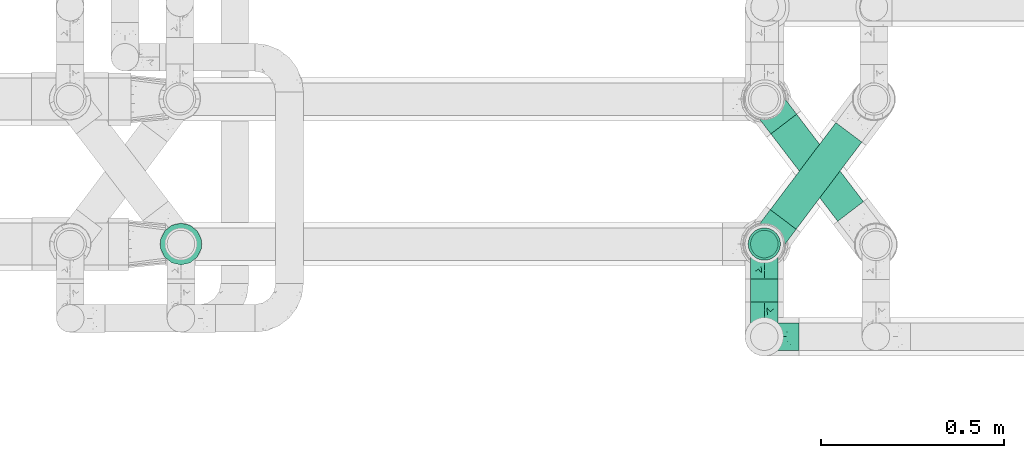
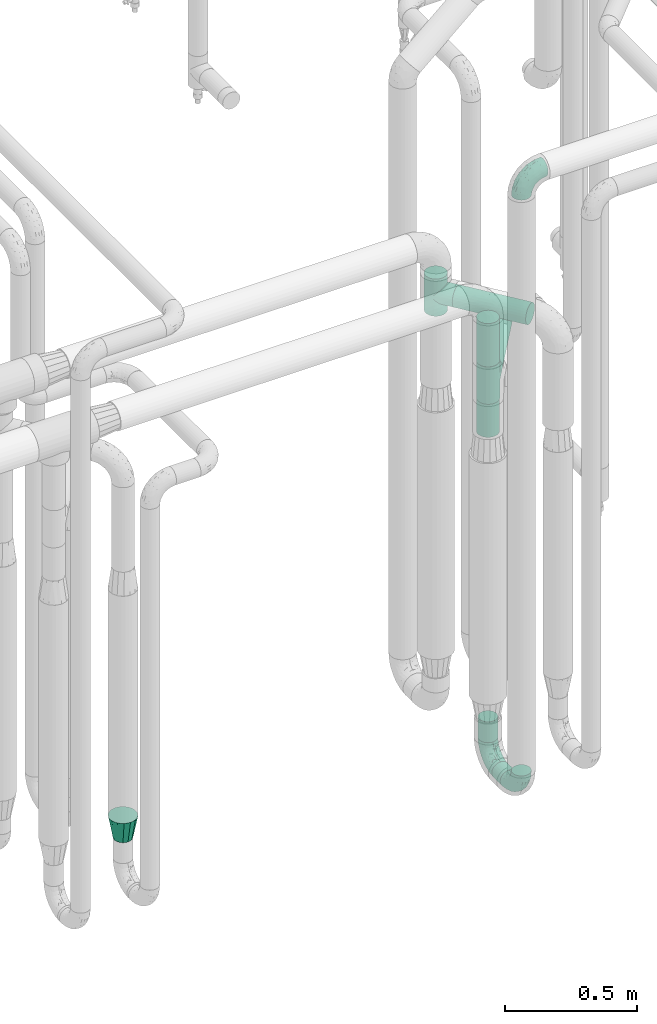
# One storey, part 658 of 827: 6 flow fittings, 6 flow segments.
"""IFC2X3 building model written with IfcOpenShell, lengths in millimetres."""

from ifc_helpers import new_model, entity, si_unit, converted_unit, derived_unit, direction, frame, origin, origin_2d_with_axis, place, context, subcontext, project, spatial, circle, extrude, faceted_brep, source, transform, mapped, material, type_object, type_shapes, element, save


model = new_model("IFC2X3")

# Units and contexts
model_context = context("Model", 3, precision=0.01, world=origin(), true_north=direction((6.12303176911189e-17, 1.0)))
body_context = subcontext(model_context, "Body", "Model", "MODEL_VIEW")
ifc_project = project(units=[si_unit("LENGTHUNIT", "METRE", prefix="MILLI"), si_unit("AREAUNIT", "SQUARE_METRE"), si_unit("VOLUMEUNIT", "CUBIC_METRE"), converted_unit("PLANEANGLEUNIT", "DEGREE", entity("IfcRatioMeasure", 0.0174532925199433), si_unit("PLANEANGLEUNIT", "RADIAN"), dimensions=[0, 0, 0, 0, 0, 0, 0]), si_unit("MASSUNIT", "GRAM", prefix="KILO"), derived_unit("MASSDENSITYUNIT", [(si_unit("MASSUNIT", "GRAM", prefix="KILO"), 1), (si_unit("LENGTHUNIT", "METRE"), -3)]), derived_unit("MOMENTOFINERTIAUNIT", [(si_unit("LENGTHUNIT", "METRE"), 4)]), si_unit("TIMEUNIT", "SECOND"), si_unit("FREQUENCYUNIT", "HERTZ"), si_unit("THERMODYNAMICTEMPERATUREUNIT", "DEGREE_CELSIUS"), derived_unit("THERMALTRANSMITTANCEUNIT", [(si_unit("MASSUNIT", "GRAM", prefix="KILO"), 1), (si_unit("THERMODYNAMICTEMPERATUREUNIT", "KELVIN"), -1), (si_unit("TIMEUNIT", "SECOND"), -3)]), derived_unit("VOLUMETRICFLOWRATEUNIT", [(si_unit("LENGTHUNIT", "METRE"), 3), (si_unit("TIMEUNIT", "SECOND"), -1)]), derived_unit("MASSFLOWRATEUNIT", [(si_unit("MASSUNIT", "GRAM", prefix="KILO"), 1), (si_unit("TIMEUNIT", "SECOND"), -1)]), derived_unit("ROTATIONALFREQUENCYUNIT", [(si_unit("TIMEUNIT", "SECOND"), -1)]), si_unit("ELECTRICCURRENTUNIT", "AMPERE"), si_unit("ELECTRICVOLTAGEUNIT", "VOLT"), si_unit("POWERUNIT", "WATT"), si_unit("FORCEUNIT", "NEWTON", prefix="KILO"), si_unit("ILLUMINANCEUNIT", "LUX"), si_unit("LUMINOUSFLUXUNIT", "LUMEN"), si_unit("LUMINOUSINTENSITYUNIT", "CANDELA"), derived_unit("USERDEFINED", [(si_unit("MASSUNIT", "GRAM", prefix="KILO"), -1), (si_unit("LENGTHUNIT", "METRE"), -2), (si_unit("TIMEUNIT", "SECOND"), 3), (si_unit("LUMINOUSFLUXUNIT", "LUMEN"), 1)]), derived_unit("LINEARVELOCITYUNIT", [(si_unit("LENGTHUNIT", "METRE"), 1), (si_unit("TIMEUNIT", "SECOND"), -1)]), si_unit("PRESSUREUNIT", "PASCAL"), derived_unit("USERDEFINED", [(si_unit("LENGTHUNIT", "METRE"), -2), (si_unit("MASSUNIT", "GRAM", prefix="KILO"), 1), (si_unit("TIMEUNIT", "SECOND"), -2)]), derived_unit("LINEARFORCEUNIT", [(si_unit("MASSUNIT", "GRAM", prefix="KILO"), 1), (si_unit("LENGTHUNIT", "METRE"), 1), (si_unit("TIMEUNIT", "SECOND"), -2), (si_unit("LENGTHUNIT", "METRE"), -1)]), derived_unit("PLANARFORCEUNIT", [(si_unit("MASSUNIT", "GRAM", prefix="KILO"), 1), (si_unit("LENGTHUNIT", "METRE"), 1), (si_unit("TIMEUNIT", "SECOND"), -2), (si_unit("LENGTHUNIT", "METRE"), -2)])], contexts=[model_context])

# Site, building, storey
site_placement = place(None, origin())
site = spatial("IfcSite", under=ifc_project, at=site_placement, CompositionType="ELEMENT")
building_placement = place(site_placement, origin())
building = spatial("IfcBuilding", under=site, at=building_placement, CompositionType="ELEMENT")
storey_placement = place(building_placement, frame((0.0, 0.0, 28200.0)))
storey = spatial("IfcBuildingStorey", under=building, at=storey_placement, Name="08", CompositionType="ELEMENT", Elevation=28200.0)

# Flow segments
pipe_segment_type = type_object("IfcPipeSegmentType", PredefinedType="NOTDEFINED")
flow_segment_1_placement = place(storey_placement, frame((45453.93, 13731.84, 310.65)))
element("IfcFlowSegment", 1, at=flow_segment_1_placement, inside=storey, type_object=pipe_segment_type, context=body_context, shape_type="SweptSolid", body=[
    extrude(circle(Radius=37.75, at=origin_2d_with_axis()), frame((39.35, 0.0, 39.35), z_axis=(0.0, 1.0, 0.0), x_axis=(1.0, 0.0, 0.0)), (0.0, 0.0, 1.0), 63.3318534116004),
])
flow_segment_2_placement = place(storey_placement, frame((45453.93, 13850.83, 445.0)))
element("IfcFlowSegment", 2, at=flow_segment_2_placement, inside=storey, type_object=pipe_segment_type, context=body_context, shape_type="SweptSolid", body=[
    extrude(circle(Radius=37.75, at=origin_2d_with_axis()), frame((39.35, 39.35, 0.0)), (0.0, 0.0, 1.0), 96.0215360887079),
])
flow_segment_3_placement = place(storey_placement, frame((45508.1, 13929.23, 2054.15)))
element("IfcFlowSegment", 3, at=flow_segment_3_placement, inside=storey, type_object=pipe_segment_type, context=body_context, shape_type="SweptSolid", body=[
    extrude(circle(Radius=44.25, at=origin_2d_with_axis()), frame((36.93, 28.23, 45.85), z_axis=(0.601815023152047, 0.798635510047294, 0.0), x_axis=(-0.798635510047294, 0.601815023152047, 0.0)), (0.0, 0.0, 1.0), 298.151313129892),
])
flow_segment_4_placement = place(storey_placement, frame((45447.43, 13844.33, 1860.0)))
element("IfcFlowSegment", 4, at=flow_segment_4_placement, inside=storey, type_object=pipe_segment_type, context=body_context, shape_type="SweptSolid", body=[
    extrude(circle(Radius=44.25, at=origin_2d_with_axis()), frame((45.85, 45.85, 0.0)), (0.0, 0.0, 1.0), 154.00000000003),
])
flow_segment_5_placement = place(storey_placement, frame((45447.43, 13844.33, 2186.0)))
element("IfcFlowSegment", 5, at=flow_segment_5_placement, inside=storey, type_object=pipe_segment_type, context=body_context, shape_type="SweptSolid", body=[
    extrude(circle(Radius=44.25, at=origin_2d_with_axis()), frame((45.85, 45.85, 0.0)), (0.0, 0.0, 1.0), 199.999999999998),
])
flow_segment_6_placement = place(storey_placement, frame((45509.72, 13950.89, 2219.15)))
element("IfcFlowSegment", 6, at=flow_segment_6_placement, inside=storey, type_object=pipe_segment_type, context=body_context, shape_type="SweptSolid", body=[
    extrude(circle(Radius=44.25, at=origin_2d_with_axis()), frame((36.74, 267.41, 45.85), z_axis=(0.607471228521976, -0.794341681216592, 0.0), x_axis=(0.794341681216592, 0.607471228521976, 0.0)), (0.0, 0.0, 1.0), 300.796301470954),
])

# Flow fittings
ifc_material = material()
pipe_fitting_type_1 = type_object("IfcPipeFittingType", Name="ADSK_1", PredefinedType="NOTDEFINED", material=ifc_material)
shared_shape_1 = source(origin(), body_context, "Body", "Brep", [
    faceted_brep([(-95.0, 19.02, -32.95), (-95.0, 9.85, -36.75), (-95.0, 0.0, -38.05), (-95.0, -9.85, -36.75), (-95.0, -19.03, -32.95), (-95.0, -26.91, -26.91), (-95.0, -32.95, -19.03), (-95.0, -36.75, -9.85), (-95.0, -38.05, 0.0), (-95.0, -36.75, 9.85), (-95.0, -32.95, 19.02), (-95.0, -26.91, 26.91), (-95.0, -19.03, 32.95), (-95.0, -9.85, 36.75), (-95.0, 0.0, 38.05), (-95.0, 9.85, 36.75), (-95.0, 19.02, 32.95), (-95.0, 26.91, 26.91), (-95.0, 32.95, 19.02), (-95.0, 36.75, 9.85), (-95.0, 38.05, 0.0), (-95.0, 36.75, -9.85), (-95.0, 32.95, -19.03), (-95.0, 26.91, -26.91), (0.0, 95.0, -38.05), (-9.85, 95.0, -36.75), (-19.02, 95.0, -32.95), (-26.91, 95.0, -26.91), (-32.95, 95.0, -19.03), (-36.75, 95.0, -9.85), (-38.05, 95.0, 0.0), (-36.75, 95.0, 9.85), (-32.95, 95.0, 19.02), (-26.91, 95.0, 26.91), (-19.02, 95.0, 32.95), (-9.85, 95.0, 36.75), (0.0, 95.0, 38.05), (9.85, 95.0, 36.75), (19.03, 95.0, 32.95), (26.91, 95.0, 26.91), (32.95, 95.0, 19.02), (36.75, 95.0, 9.85), (38.05, 95.0, 0.0), (36.75, 95.0, -9.85), (32.95, 95.0, -19.03), (26.91, 95.0, -26.91), (19.03, 95.0, -32.95), (9.85, 95.0, -36.75), (-7.99, -4.96, 6.3), (-0.92, 0.92, 0.0), (4.62, 8.1, 8.01), (-76.19, -35.57, 0.0), (-64.32, -32.32, 12.43), (20.51, 62.45, 28.68), (-60.56, -33.52, 0.0), (-70.4, -13.47, 34.42), (-39.61, -5.88, 32.32), (-49.6, 2.07, 37.1), (-70.34, -28.81, 21.71), (14.64, 40.81, 26.5), (5.88, 39.61, 32.32), (3.59, 20.77, 25.31), (-40.45, 68.06, 16.75), (-62.45, -20.51, 28.68), (-44.52, -26.87, 0.0), (-28.47, -20.22, 0.0), (-26.43, -17.83, 8.75), (-76.1, 39.63, 10.76), (-72.74, 37.58, 18.19), (-60.35, 46.18, 14.61), (-13.4, 13.4, 32.12), (-20.77, -3.59, 25.31), (-14.66, 81.47, 35.56), (-6.22, 71.26, 37.92), (-57.5, 42.48, 22.79), (-15.0, 34.74, 37.7), (-27.1, 12.08, 36.05), (-9.2, 28.81, 35.63), (-79.98, 23.7, 30.95), (-73.68, -4.3, 37.48), (-30.74, 21.67, 37.97), (-62.36, 47.59, 6.79), (-72.71, 32.83, 24.69), (-67.42, 7.02, 37.95), (-32.13, 75.27, 24.51), (-43.46, 51.47, 26.26), (-24.98, 73.15, 31.29), (20.59, 41.28, 19.85), (7.79, 16.09, 15.86), (-73.21, 42.39, 0.0), (-54.73, 54.73, 0.0), (-73.44, 15.79, 35.79), (-5.94, 4.32, 20.43), (28.81, 70.34, 21.71), (32.32, 64.32, 12.43), (-53.59, 26.2, 35.09), (-52.02, 19.31, 37.21), (21.38, 33.53, 10.34), (26.87, 44.52, 0.0), (-48.28, 12.14, 38.05), (4.3, 73.68, 37.48), (-44.08, -25.52, 12.79), (-41.28, -20.59, 19.85), (35.57, 76.19, 0.0), (-47.26, 54.3, 20.18), (-47.4, 61.99, 8.58), (-42.39, 73.21, 0.0), (-39.67, 78.86, 7.21), (-45.69, 36.84, 33.11), (-32.83, 50.13, 33.35), (13.47, 70.4, 34.42), (-18.25, 63.73, 36.07), (-40.63, -13.75, 27.22), (-16.63, 46.37, 37.95), (-53.47, 38.79, 28.59), (-26.07, 48.54, 36.15), (-34.51, 34.51, 36.86), (-2.07, 49.6, 37.1), (-22.79, -10.49, 19.23), (-61.73, 28.67, 31.87), (9.65, 14.7, 0.0), (20.22, 28.47, 0.0), (33.52, 60.56, 0.0), (-11.42, -5.44, 13.25), (-14.7, -9.65, 0.0), (-81.47, 14.66, -35.56), (-62.45, -20.51, -28.68), (-71.26, 6.22, -37.92), (-75.27, 32.13, -24.51), (-73.15, 24.98, -31.29), (13.47, 70.4, -34.42), (5.88, 39.61, -32.32), (-2.07, 49.6, -37.1), (-78.86, 39.67, -7.21), (-70.4, -13.47, -34.42), (-39.61, -5.88, -32.32), (-61.99, 47.4, -8.58), (32.32, 64.32, -12.43), (28.81, 70.34, -21.71), (-63.73, 18.25, -36.07), (-50.13, 32.83, -33.35), (4.3, 73.68, -37.48), (-7.02, 67.42, -37.95), (-39.63, 76.1, -10.76), (-46.18, 60.35, -14.61), (-47.59, 62.36, -6.79), (-64.32, -32.32, -12.43), (-26.2, 53.59, -35.09), (-15.79, 73.44, -35.79), (-19.31, 52.02, -37.21), (-37.58, 72.74, -18.19), (-70.34, -28.81, -21.71), (-42.48, 57.5, -22.79), (-38.79, 53.47, -28.59), (-51.47, 43.46, -26.26), (-32.83, 72.71, -24.69), (-46.37, 16.63, -37.95), (-73.68, -4.3, -37.48), (-41.28, -20.59, -19.85), (-44.08, -25.52, -12.79), (13.75, 40.63, -27.22), (20.51, 62.45, -28.68), (-68.06, 40.45, -16.75), (-54.3, 47.26, -20.18), (-12.14, 48.28, -38.05), (-21.67, 30.74, -37.97), (-36.84, 45.69, -33.11), (-11.42, -5.44, -13.25), (7.79, 16.09, -15.86), (4.62, 8.1, -8.01), (-23.7, 79.98, -30.95), (-26.43, -17.83, -8.75), (-7.99, -4.96, -6.3), (-40.81, -14.64, -26.5), (-20.77, -3.59, -25.31), (-34.74, 15.0, -37.7), (-12.08, 27.1, -36.05), (-28.81, 9.2, -35.63), (-22.79, -10.49, -19.23), (21.38, 33.53, -10.34), (20.59, 41.28, -19.85), (-48.54, 26.07, -36.15), (-49.6, 2.07, -37.1), (-13.4, 13.4, -32.12), (3.59, 20.77, -25.31), (-28.67, 61.73, -31.87), (-34.51, 34.51, -36.86), (-5.94, 4.32, -20.43)], [[[0, 1, 2, 3, 4, 5, 6, 7, 8, 9, 10, 11, 12, 13, 14, 15, 16, 17, 18, 19, 20, 21, 22, 23]], [[24, 25, 26, 27, 28, 29, 30, 31, 32, 33, 34, 35, 36, 37, 38, 39, 40, 41, 42, 43, 44, 45, 46, 47]], [[48, 49, 50]], [[51, 52, 9]], [[53, 39, 38]], [[9, 52, 10]], [[54, 52, 51]], [[55, 56, 57]], [[11, 10, 58]], [[59, 60, 61]], [[32, 31, 62]], [[63, 12, 11]], [[63, 55, 12]], [[64, 65, 66]], [[67, 68, 69]], [[70, 56, 71]], [[35, 72, 73]], [[69, 68, 74]], [[75, 76, 77]], [[16, 78, 17]], [[13, 79, 14]], [[76, 75, 80]], [[67, 69, 81]], [[18, 17, 82]], [[14, 79, 83]], [[20, 19, 67]], [[84, 85, 86]], [[87, 61, 88]], [[89, 81, 90]], [[18, 82, 68]], [[15, 91, 16]], [[14, 83, 15]], [[71, 92, 61]], [[17, 78, 82]], [[93, 87, 94]], [[95, 91, 96]], [[97, 98, 94]], [[86, 72, 34]], [[96, 99, 80]], [[37, 36, 100]], [[40, 39, 93]], [[40, 94, 41]], [[64, 66, 101]], [[93, 94, 40]], [[58, 102, 63]], [[94, 103, 41]], [[94, 87, 97]], [[104, 69, 74]], [[34, 33, 86]], [[105, 69, 104]], [[52, 58, 10]], [[106, 107, 30]], [[108, 109, 85]], [[105, 106, 90]], [[53, 110, 60]], [[86, 111, 72]], [[86, 109, 111]], [[33, 84, 86]], [[12, 55, 13]], [[112, 56, 63]], [[110, 38, 37]], [[34, 72, 35]], [[36, 35, 73]], [[111, 113, 73]], [[105, 107, 106]], [[110, 53, 38]], [[74, 114, 85]], [[91, 15, 83]], [[105, 90, 81]], [[107, 62, 31]], [[33, 32, 84]], [[115, 109, 116]], [[111, 115, 113]], [[100, 73, 117]], [[56, 55, 63]], [[79, 55, 57]], [[102, 118, 112]], [[56, 70, 76]], [[100, 110, 37]], [[117, 77, 60]], [[117, 60, 110]], [[60, 70, 61]], [[58, 52, 101]], [[63, 11, 58]], [[39, 53, 93]], [[87, 93, 53]], [[96, 91, 83]], [[78, 91, 119]], [[32, 62, 84]], [[84, 62, 104]], [[86, 85, 109]], [[85, 114, 108]], [[80, 113, 116]], [[117, 73, 113]], [[80, 116, 96]], [[80, 57, 76]], [[71, 112, 118]], [[61, 87, 59]], [[62, 107, 105]], [[97, 120, 121]], [[70, 71, 61]], [[71, 118, 92]], [[73, 100, 36]], [[110, 100, 117]], [[55, 79, 13]], [[83, 79, 57]], [[96, 83, 99]], [[116, 108, 95]], [[50, 97, 88]], [[97, 87, 88]], [[50, 49, 120]], [[122, 94, 98]], [[89, 20, 67]], [[105, 81, 69]], [[89, 67, 81]], [[68, 19, 18]], [[68, 67, 19]], [[74, 68, 82]], [[114, 82, 119]], [[74, 85, 104]], [[82, 114, 74]], [[114, 119, 108]], [[95, 108, 119]], [[116, 109, 108]], [[123, 48, 50]], [[97, 50, 120]], [[123, 50, 88]], [[91, 95, 119]], [[116, 95, 96]], [[84, 104, 85]], [[104, 62, 105]], [[83, 57, 99]], [[57, 80, 99]], [[66, 48, 123]], [[66, 124, 48]], [[118, 66, 123]], [[124, 66, 65]], [[66, 118, 101]], [[54, 64, 52]], [[124, 49, 48]], [[30, 107, 31]], [[91, 78, 16]], [[82, 78, 119]], [[56, 76, 57]], [[77, 76, 70]], [[60, 77, 70]], [[77, 117, 75]], [[117, 113, 75]], [[113, 80, 75]], [[9, 8, 51]], [[103, 94, 122]], [[103, 42, 41]], [[73, 72, 111]], [[113, 115, 116]], [[111, 109, 115]], [[102, 112, 63]], [[71, 56, 112]], [[118, 102, 101]], [[92, 123, 88]], [[123, 92, 118]], [[61, 92, 88]], [[87, 53, 59]], [[60, 59, 53]], [[97, 121, 98]], [[58, 101, 102]], [[64, 101, 52]], [[125, 1, 0]], [[126, 5, 4]], [[2, 1, 127]], [[1, 125, 127]], [[128, 129, 23]], [[130, 131, 132]], [[89, 133, 20]], [[126, 134, 135]], [[136, 89, 90]], [[137, 138, 44]], [[139, 129, 140]], [[24, 141, 142]], [[143, 144, 145]], [[125, 129, 139]], [[6, 146, 7]], [[147, 148, 149]], [[146, 51, 7]], [[143, 150, 144]], [[146, 6, 151]], [[152, 153, 154]], [[126, 4, 134]], [[0, 23, 129]], [[28, 155, 150]], [[43, 42, 103]], [[54, 146, 64]], [[139, 156, 127]], [[157, 3, 2]], [[151, 158, 159]], [[160, 131, 161]], [[22, 21, 162]], [[136, 144, 163]], [[149, 164, 165]], [[24, 142, 25]], [[166, 140, 154]], [[154, 129, 128]], [[143, 30, 29]], [[167, 168, 169]], [[155, 28, 27]], [[26, 170, 27]], [[171, 167, 172]], [[26, 25, 148]], [[27, 170, 155]], [[173, 135, 174]], [[144, 150, 152]], [[175, 176, 177]], [[24, 47, 141]], [[45, 161, 46]], [[148, 25, 142]], [[176, 175, 165]], [[64, 159, 171]], [[138, 45, 44]], [[130, 46, 161]], [[137, 44, 43]], [[178, 159, 158]], [[137, 103, 122]], [[163, 144, 152]], [[136, 133, 89]], [[103, 137, 43]], [[6, 5, 151]], [[178, 158, 173]], [[134, 4, 3]], [[178, 173, 174]], [[137, 98, 179]], [[145, 90, 106]], [[138, 180, 161]], [[46, 130, 47]], [[136, 90, 145]], [[133, 162, 21]], [[23, 22, 128]], [[139, 140, 181]], [[139, 181, 156]], [[157, 127, 182]], [[157, 134, 3]], [[182, 177, 135]], [[182, 135, 134]], [[135, 183, 174]], [[131, 130, 161]], [[141, 130, 132]], [[160, 180, 184]], [[131, 183, 176]], [[5, 126, 151]], [[158, 151, 126]], [[180, 138, 137]], [[161, 45, 138]], [[149, 148, 142]], [[170, 148, 185]], [[22, 162, 128]], [[128, 162, 163]], [[129, 154, 140]], [[154, 153, 166]], [[165, 156, 186]], [[182, 127, 156]], [[165, 186, 149]], [[165, 132, 176]], [[131, 184, 183]], [[187, 167, 178]], [[184, 168, 187]], [[167, 169, 172]], [[184, 180, 168]], [[174, 183, 184]], [[127, 157, 2]], [[134, 157, 182]], [[130, 141, 47]], [[142, 141, 132]], [[149, 142, 164]], [[186, 166, 147]], [[180, 179, 168]], [[169, 179, 120]], [[137, 179, 180]], [[179, 121, 120]], [[106, 30, 143]], [[136, 145, 144]], [[106, 143, 145]], [[150, 29, 28]], [[150, 143, 29]], [[152, 150, 155]], [[153, 155, 185]], [[152, 154, 163]], [[155, 153, 152]], [[153, 185, 166]], [[147, 166, 185]], [[186, 140, 166]], [[169, 120, 49]], [[169, 49, 172]], [[179, 169, 168]], [[148, 147, 185]], [[186, 147, 149]], [[128, 163, 154]], [[163, 162, 136]], [[142, 132, 164]], [[132, 165, 164]], [[171, 124, 65]], [[124, 171, 172]], [[64, 146, 159]], [[171, 159, 178]], [[171, 65, 64]], [[172, 49, 124]], [[162, 133, 136]], [[20, 133, 21]], [[148, 170, 26]], [[155, 170, 185]], [[131, 176, 132]], [[177, 176, 183]], [[135, 177, 183]], [[177, 182, 175]], [[182, 156, 175]], [[156, 165, 175]], [[51, 146, 54]], [[51, 8, 7]], [[129, 125, 0]], [[127, 125, 139]], [[140, 186, 181]], [[156, 181, 186]], [[158, 126, 173]], [[135, 173, 126]], [[187, 178, 174]], [[171, 178, 167]], [[184, 187, 174]], [[167, 187, 168]], [[180, 160, 161]], [[184, 131, 160]], [[98, 137, 122]], [[98, 121, 179]], [[151, 159, 146]]]),
])
type_shapes(pipe_fitting_type_1, [shared_shape_1])
for number, where, z_axis, x_axis, name in (
    (7, (45493.28, 13636.84, 350.0), (1.0, 0.0, 0.0), (0.0, 0.0, -1.0), "ADSK_1"),
    (8, (45493.28, 13890.17, 350.0), (1.0, 0.0, 0.0), (0.0, 1.0, 0.0), "ADSK_1"),
    (9, (45493.28, 13636.84, 3200.05), (0.0, 1.0, 0.0), (0.0, 0.0, 1.0), "ADSK_1"),
):
    element("IfcFlowFitting", number, at=place(storey_placement, frame(where, z_axis=z_axis, x_axis=x_axis)), inside=storey, type_object=pipe_fitting_type_1, material=ifc_material, Name=name, ObjectType="ADSK_1", context=body_context, shape_type="MappedRepresentation", body=[
        mapped(shared_shape_1, transform((0.0, 0.0, 0.0), scale=1.0)),
    ])
pipe_fitting_type_2 = type_object("IfcPipeFittingType", Name="ADSK_1", PredefinedType="NOTDEFINED", material=ifc_material)
shared_shape_2 = source(origin(), body_context, "Body", "Brep", [
    faceted_brep([(-86.0, 22.22, -38.49), (-86.0, 11.5, -42.94), (-86.0, 0.0, -44.45), (-86.0, -11.5, -42.94), (-86.0, -22.23, -38.49), (-86.0, -26.83, -34.96), (-86.0, -31.43, -31.43), (-86.0, -34.96, -26.83), (-86.0, -38.49, -22.23), (-86.0, -40.72, -16.86), (-86.0, -42.94, -11.5), (-86.0, -44.45, 0.0), (-86.0, -42.94, 11.5), (-86.0, -40.72, 16.86), (-86.0, -38.49, 22.22), (-86.0, -34.96, 26.83), (-86.0, -31.43, 31.43), (-86.0, -26.83, 34.96), (-86.0, -22.23, 38.49), (-86.0, -11.5, 42.94), (-86.0, 0.0, 44.45), (-86.0, 11.5, 42.94), (-86.0, 22.22, 38.49), (-86.0, 31.43, 31.43), (-86.0, 38.49, 22.22), (-86.0, 42.94, 11.5), (-86.0, 44.45, 0.0), (-86.0, 42.94, -11.5), (-86.0, 38.49, -22.23), (-86.0, 31.43, -31.43), (86.0, 0.0, -44.45), (86.0, 11.5, -42.94), (86.0, 22.22, -38.49), (86.0, 31.43, -31.43), (86.0, 38.49, -22.23), (86.0, 42.94, -11.5), (86.0, 44.45, 0.0), (86.0, 42.94, 11.5), (86.0, 38.49, 22.22), (86.0, 31.43, 31.43), (86.0, 22.22, 38.49), (86.0, 11.5, 42.94), (86.0, 0.0, 44.45), (86.0, -11.5, 42.94), (86.0, -22.23, 38.49), (86.0, -26.83, 34.96), (86.0, -31.43, 31.43), (86.0, -34.96, 26.83), (86.0, -38.49, 22.22), (86.0, -40.72, 16.86), (86.0, -42.94, 11.5), (86.0, -44.45, 0.0), (86.0, -42.94, -11.5), (86.0, -40.72, -16.86), (86.0, -38.49, -22.23), (86.0, -34.96, -26.83), (86.0, -31.43, -31.43), (86.0, -26.83, -34.96), (86.0, -22.23, -38.49), (86.0, -11.5, -42.94), (43.21, -43.21, 10.43), (44.45, -44.45, 0.0), (-43.21, -43.21, 10.43), (-44.45, -44.45, 0.0), (41.49, -41.49, 15.14), (39.77, -39.77, 19.85), (21.97, -21.97, 38.64), (34.75, -34.75, 27.71), (28.69, -28.69, 33.95), (-41.49, -41.49, 15.14), (-39.77, -39.77, 19.85), (-21.97, -21.97, 38.64), (-34.75, -34.75, 27.71), (-28.69, -28.69, 33.95), (-14.84, -14.84, 41.9), (7.47, -7.47, 43.82), (14.84, -14.84, 41.9), (0.0, 0.0, 44.45), (-7.47, -7.47, 43.82), (7.47, -7.47, -43.82), (0.0, 0.0, -44.45), (14.84, -14.84, -41.9), (-28.69, -28.69, -33.95), (-7.47, -7.47, -43.82), (-41.49, -41.49, -15.14), (-43.21, -43.21, -10.43), (-34.75, -34.75, -27.71), (-14.84, -14.84, -41.9), (21.97, -21.97, -38.64), (28.69, -28.69, -33.95), (-39.77, -39.77, -19.85), (34.75, -34.75, -27.71), (43.21, -43.21, -10.43), (41.49, -41.49, -15.14), (39.77, -39.77, -19.85), (-21.97, -21.97, -38.64), (31.43, -86.0, -31.43), (38.49, -86.0, -22.23), (42.94, -86.0, -11.5), (44.45, -86.0, 0.0), (42.94, -86.0, 11.5), (38.49, -86.0, 22.22), (31.43, -86.0, 31.43), (22.23, -86.0, 38.49), (11.5, -86.0, 42.94), (0.0, -86.0, 44.45), (-11.5, -86.0, 42.94), (-22.22, -86.0, 38.49), (-31.43, -86.0, 31.43), (-38.49, -86.0, 22.22), (-42.94, -86.0, 11.5), (-44.45, -86.0, 0.0), (-42.94, -86.0, -11.5), (-38.49, -86.0, -22.23), (-31.43, -86.0, -31.43), (-22.22, -86.0, -38.49), (-11.5, -86.0, -42.94), (0.0, -86.0, -44.45), (11.5, -86.0, -42.94), (22.23, -86.0, -38.49)], [[[0, 1, 2, 3, 4, 5, 6, 7, 8, 9, 10, 11, 12, 13, 14, 15, 16, 17, 18, 19, 20, 21, 22, 23, 24, 25, 26, 27, 28, 29]], [[30, 31, 32, 33, 34, 35, 36, 37, 38, 39, 40, 41, 42, 43, 44, 45, 46, 47, 48, 49, 50, 51, 52, 53, 54, 55, 56, 57, 58, 59]], [[51, 50, 60]], [[60, 61, 51]], [[62, 11, 63]], [[50, 49, 64]], [[49, 48, 65]], [[44, 66, 45]], [[46, 67, 48, 47]], [[67, 46, 68]], [[48, 67, 65]], [[68, 46, 45]], [[12, 69, 13]], [[70, 13, 69]], [[11, 62, 12]], [[12, 62, 69]], [[71, 18, 17]], [[72, 73, 16]], [[72, 16, 15, 14]], [[16, 73, 17]], [[71, 74, 18]], [[72, 14, 70]], [[49, 65, 64]], [[45, 66, 68]], [[43, 42, 75]], [[50, 64, 60]], [[66, 44, 76]], [[75, 76, 43]], [[75, 42, 77]], [[78, 77, 20]], [[76, 44, 43]], [[24, 23, 39, 38]], [[25, 24, 38, 37]], [[22, 21, 41, 40]], [[23, 22, 40, 39]], [[41, 21, 20, 77, 42]], [[26, 25, 37, 36]], [[70, 14, 13]], [[78, 19, 74]], [[19, 78, 20]], [[19, 18, 74]], [[71, 17, 73]], [[29, 28, 34, 33]], [[27, 35, 34, 28]], [[26, 36, 35, 27]], [[0, 29, 33, 32]], [[30, 59, 79]], [[31, 30, 80, 2, 1]], [[79, 59, 81]], [[82, 6, 5]], [[32, 31, 1, 0]], [[59, 58, 81]], [[30, 79, 80]], [[80, 83, 2]], [[10, 84, 85]], [[86, 8, 7, 6]], [[83, 87, 3]], [[2, 83, 3]], [[87, 4, 3]], [[88, 57, 89]], [[57, 56, 89]], [[9, 90, 84]], [[88, 58, 57]], [[91, 89, 56]], [[55, 54, 91, 56]], [[58, 88, 81]], [[52, 92, 93]], [[92, 52, 51]], [[94, 53, 93]], [[61, 92, 51]], [[85, 63, 11]], [[54, 94, 91]], [[82, 5, 95]], [[52, 93, 53]], [[5, 4, 95]], [[6, 82, 86]], [[94, 54, 53]], [[95, 4, 87]], [[10, 9, 84]], [[90, 9, 8]], [[10, 85, 11]], [[90, 8, 86]], [[96, 97, 98, 99, 100, 101, 102, 103, 104, 105, 106, 107, 108, 109, 110, 111, 112, 113, 114, 115, 116, 117, 118, 119]], [[62, 63, 111]], [[110, 62, 111]], [[108, 107, 73]], [[72, 109, 108]], [[70, 110, 109]], [[74, 107, 106]], [[110, 70, 69, 62]], [[73, 72, 108]], [[70, 109, 72]], [[74, 71, 107]], [[105, 77, 78]], [[74, 106, 78]], [[73, 107, 71]], [[78, 106, 105]], [[75, 105, 104]], [[103, 76, 104]], [[101, 100, 65]], [[67, 102, 101]], [[68, 103, 102]], [[60, 100, 99]], [[68, 66, 103]], [[76, 75, 104]], [[66, 76, 103]], [[61, 60, 99]], [[65, 67, 101]], [[100, 60, 64, 65]], [[68, 102, 67]], [[105, 75, 77]], [[61, 99, 92]], [[98, 92, 99]], [[96, 119, 89]], [[94, 98, 97]], [[96, 91, 97]], [[81, 119, 118]], [[98, 94, 93, 92]], [[89, 91, 96]], [[94, 97, 91]], [[81, 88, 119]], [[117, 80, 79]], [[81, 118, 79]], [[89, 119, 88]], [[79, 118, 117]], [[83, 117, 116]], [[115, 87, 116]], [[113, 112, 90]], [[86, 114, 113]], [[82, 115, 114]], [[85, 112, 111]], [[82, 95, 115]], [[87, 83, 116]], [[95, 87, 115]], [[63, 85, 111]], [[90, 86, 113]], [[112, 85, 84, 90]], [[82, 114, 86]], [[117, 83, 80]]]),
])
type_shapes(pipe_fitting_type_2, [shared_shape_2])
for number, where, z_axis, x_axis, name in (
    (10, (45493.28, 13888.78, 2100.0), (0.798635510047291, -0.601815023152051, 0.0), (0.0, 0.0, 1.0), "ADSK_1"),
    (11, (45494.22, 14286.62, 2265.0), (-0.794341681216582, -0.607471228521989, 0.0), (0.0, 0.0, 1.0), "ADSK_1"),
):
    element("IfcFlowFitting", number, at=place(storey_placement, frame(where, z_axis=z_axis, x_axis=x_axis)), inside=storey, type_object=pipe_fitting_type_2, material=ifc_material, Name=name, ObjectType="ADSK_1", context=body_context, shape_type="MappedRepresentation", body=[
        mapped(shared_shape_2, transform((0.0, 0.0, 0.0), scale=1.0)),
    ])
pipe_fitting_type_3 = type_object("IfcPipeFittingType", Name="ADSK_1", PredefinedType="NOTDEFINED", material=ifc_material)
shared_shape_3 = source(origin(), body_context, "Body", "Brep", [
    faceted_brep([(102.0, 38.05, 0.0), (102.0, 35.5, 9.51), (102.0, 32.95, 19.03), (102.0, 25.99, 25.99), (102.0, 19.02, 32.95), (102.0, 9.51, 35.5), (102.0, 0.0, 38.05), (102.0, -9.51, 35.5), (102.0, -19.03, 32.95), (102.0, -25.99, 25.99), (102.0, -32.95, 19.03), (102.0, -35.5, 9.51), (102.0, -38.05, 0.0), (102.0, -35.5, -9.51), (102.0, -32.95, -19.02), (102.0, -25.99, -25.99), (102.0, -19.03, -32.95), (102.0, -9.51, -35.5), (102.0, 0.0, -38.05), (102.0, 9.51, -35.5), (102.0, 19.02, -32.95), (102.0, 25.99, -25.99), (102.0, 32.95, -19.02), (102.0, 35.5, -9.51), (0.0, 43.56, 34.74), (0.0, 51.49, 24.8), (0.0, 54.32, 12.4), (0.0, 57.15, 0.0), (0.0, 54.32, -12.4), (0.0, 51.49, -24.8), (0.0, 43.56, -34.74), (0.0, 35.63, -44.68), (0.0, 24.17, -50.2), (0.0, 12.72, -55.72), (0.0, 0.0, -55.72), (0.0, -12.72, -55.72), (0.0, -24.17, -50.2), (0.0, -35.63, -44.68), (0.0, -43.56, -34.74), (0.0, -51.49, -24.8), (0.0, -54.32, -12.4), (0.0, -57.15, 0.0), (0.0, -54.32, 12.4), (0.0, -51.49, 24.8), (0.0, -43.56, 34.74), (0.0, -35.63, 44.68), (0.0, -24.17, 50.2), (0.0, -12.72, 55.72), (0.0, 0.0, 55.72), (0.0, 12.72, 55.72), (0.0, 24.17, 50.2), (0.0, 35.63, 44.68)], [[[0, 1, 2, 3, 4, 5, 6, 7, 8, 9, 10, 11, 12, 13, 14, 15, 16, 17, 18, 19, 20, 21, 22, 23]], [[24, 25, 26, 27, 28, 29, 30, 31, 32, 33, 34, 35, 36, 37, 38, 39, 40, 41, 42, 43, 44, 45, 46, 47, 48, 49, 50, 51]], [[32, 31, 20]], [[40, 12, 41]], [[30, 29, 22]], [[22, 29, 23]], [[40, 39, 13]], [[12, 40, 13]], [[37, 16, 15]], [[18, 35, 34, 33]], [[16, 37, 36]], [[32, 19, 33]], [[36, 17, 16]], [[22, 21, 30]], [[38, 14, 39]], [[23, 29, 28]], [[21, 31, 30]], [[0, 28, 27]], [[36, 35, 17]], [[0, 23, 28]], [[39, 14, 13]], [[14, 38, 15]], [[21, 20, 31]], [[19, 18, 33]], [[35, 18, 17]], [[38, 37, 15]], [[19, 32, 20]], [[46, 45, 8]], [[26, 0, 27]], [[44, 43, 10]], [[10, 43, 11]], [[26, 25, 1]], [[0, 26, 1]], [[51, 4, 3]], [[6, 49, 48, 47]], [[4, 51, 50]], [[46, 7, 47]], [[50, 5, 4]], [[10, 9, 44]], [[24, 2, 25]], [[11, 43, 42]], [[9, 45, 44]], [[12, 42, 41]], [[50, 49, 5]], [[12, 11, 42]], [[25, 2, 1]], [[2, 24, 3]], [[9, 8, 45]], [[7, 6, 47]], [[49, 6, 5]], [[24, 51, 3]], [[7, 46, 8]]]),
])
type_shapes(pipe_fitting_type_3, [shared_shape_3])
flow_fitting_placement = place(storey_placement, frame((43898.22, 13890.17, 643.02), z_axis=(1.0, 0.0, 0.0), x_axis=(0.0, 0.0, -1.0)))
element("IfcFlowFitting", 12, at=flow_fitting_placement, inside=storey, type_object=pipe_fitting_type_3, material=ifc_material, Name="ADSK_1", ObjectType="ADSK_1", context=body_context, shape_type="MappedRepresentation", body=[
    mapped(shared_shape_3, transform((0.0, 0.0, 0.0), scale=1.0)),
])

save(model, "model.ifc")
